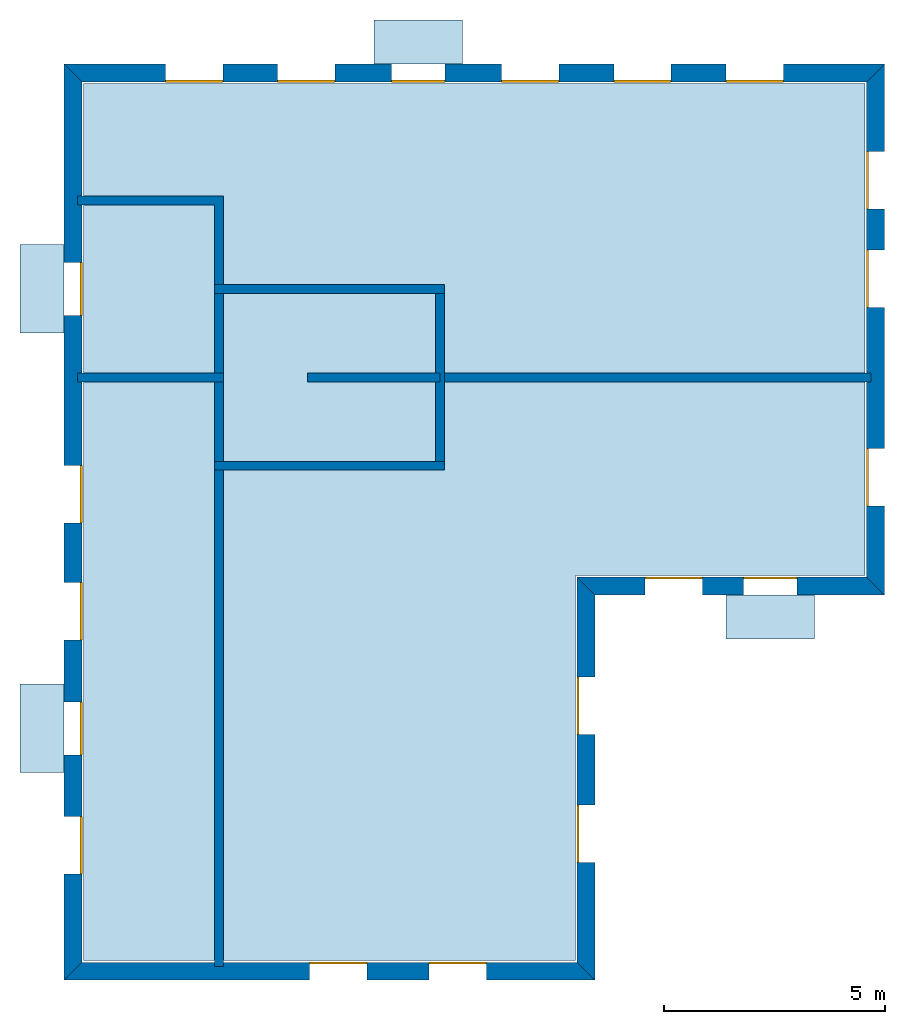
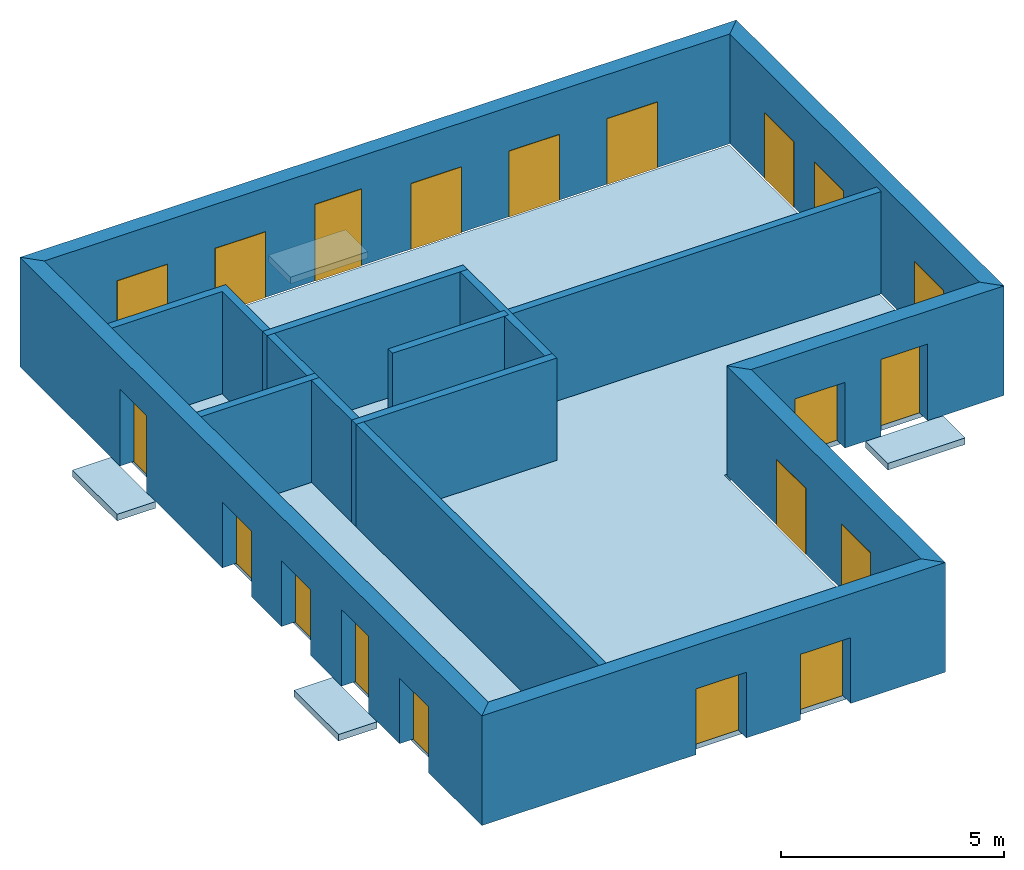
# One storey: 20 windows, 15 walls, 5 slabs, 20 openings.
"""IFC4 building model written with IfcOpenShell, lengths in metres."""

from ifc_helpers import new_model, si_unit, frame, origin_with_axes, place, context, subcontext, project, spatial, line, indexed_curve, outline, extrude, element, fill, save


model = new_model("IFC4")

# Units and contexts
model_context = context("Model", 3, precision=1e-05, world=origin_with_axes())
body_context = subcontext(model_context, "Body", "Model", "MODEL_VIEW")
ifc_project = project(units=[si_unit("AREAUNIT", "SQUARE_METRE"), si_unit("VOLUMEUNIT", "CUBIC_METRE"), si_unit("LENGTHUNIT", "METRE")], contexts=[model_context])

# Site, building, storey
site = spatial("IfcSite", under=ifc_project)
building = spatial("IfcBuilding", under=site, Name="Building 1")
storey_placement = place(None, frame((0.0, 0.0, 4.0), z_axis=(0.0, 0.0, 1.0), x_axis=(1.0, 0.0, 0.0)))
storey = spatial("IfcBuildingStorey", under=building, at=storey_placement, Name="02 Storey")

# Slabs
slab_1_placement = place(storey_placement, origin_with_axes())
element("IfcSlab", 1, at=slab_1_placement, inside=storey, Name="Slab", context=body_context, shape_type="SweptSolid", body=[
    extrude(outline(indexed_curve([(15.553354, 14.695575), (22.099464, 14.695575), (22.099464, 25.815575), (4.433354, 25.815575), (4.433354, 5.9882), (15.553354, 5.9882)], segments=[line(1, 2), line(2, 3), line(3, 4), line(4, 5), line(5, 6)])), origin_with_axes(), (0.0, 0.0, -1.0), 0.2),
])
slab_2_placement = place(storey_placement, origin_with_axes())
element("IfcSlab", 2, at=slab_2_placement, inside=storey, Name="Balcony", context=body_context, shape_type="SweptSolid", body=[
    extrude(outline(indexed_curve([(20.9574273333333, 14.255575), (20.9574273333333, 13.255575), (18.9574273333333, 13.255575), (18.9574273333333, 14.255575)], segments=[line(1, 2), line(2, 3), line(3, 4)])), origin_with_axes(), (0.0, 0.0, -1.0), 0.18),
])
slab_3_placement = place(storey_placement, origin_with_axes())
element("IfcSlab", 3, at=slab_3_placement, inside=storey, Name="Balcony", context=body_context, shape_type="SweptSolid", body=[
    extrude(outline(indexed_curve([(10.9988297142857, 26.255575), (10.9988297142857, 27.255575), (12.9988297142857, 27.255575), (12.9988297142857, 26.255575)], segments=[line(1, 2), line(2, 3), line(3, 4)])), origin_with_axes(), (0.0, 0.0, -1.0), 0.18),
])
slab_4_placement = place(storey_placement, origin_with_axes())
element("IfcSlab", 4, at=slab_4_placement, inside=storey, Name="Balcony", context=body_context, shape_type="SweptSolid", body=[
    extrude(outline(indexed_curve([(3.993354, 10.2388972), (2.993354, 10.2388972), (2.993354, 12.2388972), (3.993354, 12.2388972)], segments=[line(1, 2), line(2, 3), line(3, 4)])), origin_with_axes(), (0.0, 0.0, -1.0), 0.18),
])
slab_5_placement = place(storey_placement, origin_with_axes())
element("IfcSlab", 5, at=slab_5_placement, inside=storey, Name="Balcony", context=body_context, shape_type="SweptSolid", body=[
    extrude(outline(indexed_curve([(3.993354, 20.174943), (2.993354, 20.174943), (2.993354, 22.174943), (3.993354, 22.174943)], segments=[line(1, 2), line(2, 3), line(3, 4)])), origin_with_axes(), (0.0, 0.0, -1.0), 0.18),
])

# Walls
wall_1_placement = place(storey_placement, origin_with_axes())
element("IfcWall", 6, at=wall_1_placement, inside=storey, Name="Wall", context=body_context, shape_type="SweptSolid", body=[
    extrude(outline(indexed_curve([(22.239464, 19.274943), (12.393354, 19.274943), (12.393354, 19.074943), (22.239464, 19.074943)], segments=[line(1, 2), line(2, 3), line(3, 4)])), origin_with_axes(), (0.0, 0.0, 1.0), 2.8),
])
wall_2_placement = place(storey_placement, origin_with_axes())
element("IfcWall", 7, at=wall_2_placement, inside=storey, Name="Wall", context=body_context, shape_type="SweptSolid", body=[
    extrude(outline(indexed_curve([(7.593354, 17.274943), (7.393354, 17.274943), (7.393354, 5.8482), (7.593354, 5.8482)], segments=[line(1, 2), line(2, 3), line(3, 4)])), origin_with_axes(), (0.0, 0.0, 1.0), 2.8),
])
wall_3_placement = place(storey_placement, origin_with_axes())
element("IfcWall", 8, at=wall_3_placement, inside=storey, Name="Wall", context=body_context, shape_type="SweptSolid", body=[
    extrude(outline(indexed_curve([(7.593354, 19.274943), (4.293354, 19.274943), (4.293354, 19.074943), (7.593354, 19.074943)], segments=[line(1, 2), line(2, 3), line(3, 4)])), origin_with_axes(), (0.0, 0.0, 1.0), 2.8),
])
wall_4_placement = place(storey_placement, origin_with_axes())
element("IfcWall", 9, at=wall_4_placement, inside=storey, Name="Wall", context=body_context, shape_type="SweptSolid", body=[
    extrude(outline(indexed_curve([(7.593354, 23.274943), (4.293354, 23.274943), (4.293354, 23.074943), (7.393354, 23.074943), (7.393354, 21.074943), (7.593354, 21.074943)], segments=[line(1, 2), line(2, 3), line(3, 4), line(4, 5), line(5, 6)])), origin_with_axes(), (0.0, 0.0, 1.0), 2.8),
])

# Wall, openings, windows
wall_5_placement = place(storey_placement, origin_with_axes())
wall_5 = element("IfcWall", 10, at=wall_5_placement, inside=storey, Name="Facade", context=body_context, shape_type="SweptSolid", body=[
    extrude(outline(indexed_curve([(15.593354, 14.655575), (22.139464, 14.655575), (22.539464, 14.255575), (15.993354, 14.255575)], segments=[line(1, 2), line(2, 3), line(3, 4)])), origin_with_axes(), (0.0, 0.0, 1.0), 3.0),
])
opening_1_placement = place(wall_5_placement, origin_with_axes())
opening_1 = element("IfcOpeningElement", 11, at=opening_1_placement, cuts=wall_5, Name="Opening", context=body_context, shape_type="SweptSolid", body=[
    extrude(outline(indexed_curve([(17.1253906666667, 14.215575), (17.1253906666667, 14.715575), (18.4253906666667, 14.715575), (18.4253906666667, 14.215575)], segments=[line(1, 2), line(2, 3), line(3, 4)])), origin_with_axes(), (0.0, 0.0, 1.0), 1.8),
])
opening_2_placement = place(wall_5_placement, origin_with_axes())
opening_2 = element("IfcOpeningElement", 12, at=opening_2_placement, cuts=wall_5, Name="Opening", context=body_context, shape_type="SweptSolid", body=[
    extrude(outline(indexed_curve([(19.3574273333333, 14.215575), (19.3574273333333, 14.715575), (20.5574273333333, 14.715575), (20.5574273333333, 14.215575)], segments=[line(1, 2), line(2, 3), line(3, 4)])), origin_with_axes(), (0.0, 0.0, 1.0), 2.1),
])
window_1_placement = place(storey_placement, origin_with_axes())
window_1 = element("IfcWindow", 13, at=window_1_placement, inside=storey, Name="Window", PredefinedType="WINDOW", context=body_context, shape_type="SweptSolid", body=[
    extrude(outline(indexed_curve([(17.1253906666667, 14.615575), (17.1253906666667, 14.665575), (18.4253906666667, 14.665575), (18.4253906666667, 14.615575)], segments=[line(1, 2), line(2, 3), line(3, 4)])), origin_with_axes(), (0.0, 0.0, 1.0), 1.8),
])
fill(opening_1, window_1)
window_2_placement = place(storey_placement, origin_with_axes())
window_2 = element("IfcWindow", 14, at=window_2_placement, inside=storey, Name="Window", PredefinedType="WINDOW", context=body_context, shape_type="SweptSolid", body=[
    extrude(outline(indexed_curve([(19.3574273333333, 14.615575), (19.3574273333333, 14.665575), (20.5574273333333, 14.665575), (20.5574273333333, 14.615575)], segments=[line(1, 2), line(2, 3), line(3, 4)])), origin_with_axes(), (0.0, 0.0, 1.0), 2.1),
])
fill(opening_2, window_2)

wall_6_placement = place(storey_placement, origin_with_axes())
wall_6 = element("IfcWall", 15, at=wall_6_placement, inside=storey, Name="Facade", context=body_context, shape_type="SweptSolid", body=[
    extrude(outline(indexed_curve([(22.139464, 14.655575), (22.139464, 25.855575), (22.539464, 26.255575), (22.539464, 14.255575)], segments=[line(1, 2), line(2, 3), line(3, 4)])), origin_with_axes(), (0.0, 0.0, 1.0), 3.0),
])
opening_3_placement = place(wall_6_placement, origin_with_axes())
opening_3 = element("IfcOpeningElement", 16, at=opening_3_placement, cuts=wall_6, Name="Opening", context=body_context, shape_type="SweptSolid", body=[
    extrude(outline(indexed_curve([(22.579464, 16.265259), (22.079464, 16.265259), (22.079464, 17.565259), (22.579464, 17.565259)], segments=[line(1, 2), line(2, 3), line(3, 4)])), origin_with_axes(), (0.0, 0.0, 1.0), 1.8),
])
opening_4_placement = place(wall_6_placement, origin_with_axes())
opening_4 = element("IfcOpeningElement", 17, at=opening_4_placement, cuts=wall_6, Name="Opening", context=body_context, shape_type="SweptSolid", body=[
    extrude(outline(indexed_curve([(22.579464, 20.7518203333333), (22.079464, 20.7518203333333), (22.079464, 22.0518203333333), (22.579464, 22.0518203333333)], segments=[line(1, 2), line(2, 3), line(3, 4)])), origin_with_axes(), (0.0, 0.0, 1.0), 1.8),
])
opening_5_placement = place(wall_6_placement, origin_with_axes())
opening_5 = element("IfcOpeningElement", 18, at=opening_5_placement, cuts=wall_6, Name="Opening", context=body_context, shape_type="SweptSolid", body=[
    extrude(outline(indexed_curve([(22.579464, 22.9786976666667), (22.079464, 22.9786976666667), (22.079464, 24.2786976666667), (22.579464, 24.2786976666667)], segments=[line(1, 2), line(2, 3), line(3, 4)])), origin_with_axes(), (0.0, 0.0, 1.0), 1.8),
])
window_3_placement = place(storey_placement, origin_with_axes())
window_3 = element("IfcWindow", 19, at=window_3_placement, inside=storey, Name="Window", PredefinedType="WINDOW", context=body_context, shape_type="SweptSolid", body=[
    extrude(outline(indexed_curve([(22.179464, 16.265259), (22.129464, 16.265259), (22.129464, 17.565259), (22.179464, 17.565259)], segments=[line(1, 2), line(2, 3), line(3, 4)])), origin_with_axes(), (0.0, 0.0, 1.0), 1.8),
])
fill(opening_3, window_3)
window_4_placement = place(storey_placement, origin_with_axes())
window_4 = element("IfcWindow", 20, at=window_4_placement, inside=storey, Name="Window", PredefinedType="WINDOW", context=body_context, shape_type="SweptSolid", body=[
    extrude(outline(indexed_curve([(22.179464, 20.7518203333333), (22.129464, 20.7518203333333), (22.129464, 22.0518203333333), (22.179464, 22.0518203333333)], segments=[line(1, 2), line(2, 3), line(3, 4)])), origin_with_axes(), (0.0, 0.0, 1.0), 1.8),
])
fill(opening_4, window_4)
window_5_placement = place(storey_placement, origin_with_axes())
window_5 = element("IfcWindow", 21, at=window_5_placement, inside=storey, Name="Window", PredefinedType="WINDOW", context=body_context, shape_type="SweptSolid", body=[
    extrude(outline(indexed_curve([(22.179464, 22.9786976666667), (22.129464, 22.9786976666667), (22.129464, 24.2786976666667), (22.179464, 24.2786976666667)], segments=[line(1, 2), line(2, 3), line(3, 4)])), origin_with_axes(), (0.0, 0.0, 1.0), 1.8),
])
fill(opening_5, window_5)

wall_7_placement = place(storey_placement, origin_with_axes())
wall_7 = element("IfcWall", 22, at=wall_7_placement, inside=storey, Name="Facade", context=body_context, shape_type="SweptSolid", body=[
    extrude(outline(indexed_curve([(22.139464, 25.855575), (4.393354, 25.855575), (3.993354, 26.255575), (22.539464, 26.255575)], segments=[line(1, 2), line(2, 3), line(3, 4)])), origin_with_axes(), (0.0, 0.0, 1.0), 3.0),
])
opening_6_placement = place(wall_7_placement, origin_with_axes())
opening_6 = element("IfcOpeningElement", 23, at=opening_6_placement, cuts=wall_7, Name="Opening", context=body_context, shape_type="SweptSolid", body=[
    extrude(outline(indexed_curve([(20.2543054285714, 26.295575), (20.2543054285714, 25.795575), (18.9543054285714, 25.795575), (18.9543054285714, 26.295575)], segments=[line(1, 2), line(2, 3), line(3, 4)])), origin_with_axes(), (0.0, 0.0, 1.0), 1.8),
])
opening_7_placement = place(wall_7_placement, origin_with_axes())
opening_7 = element("IfcOpeningElement", 24, at=opening_7_placement, cuts=wall_7, Name="Opening", context=body_context, shape_type="SweptSolid", body=[
    extrude(outline(indexed_curve([(17.7191468571429, 26.295575), (17.7191468571429, 25.795575), (16.4191468571429, 25.795575), (16.4191468571429, 26.295575)], segments=[line(1, 2), line(2, 3), line(3, 4)])), origin_with_axes(), (0.0, 0.0, 1.0), 1.8),
])
opening_8_placement = place(wall_7_placement, origin_with_axes())
opening_8 = element("IfcOpeningElement", 25, at=opening_8_placement, cuts=wall_7, Name="Opening", context=body_context, shape_type="SweptSolid", body=[
    extrude(outline(indexed_curve([(15.1839882857143, 26.295575), (15.1839882857143, 25.795575), (13.8839882857143, 25.795575), (13.8839882857143, 26.295575)], segments=[line(1, 2), line(2, 3), line(3, 4)])), origin_with_axes(), (0.0, 0.0, 1.0), 1.8),
])
opening_9_placement = place(wall_7_placement, origin_with_axes())
opening_9 = element("IfcOpeningElement", 26, at=opening_9_placement, cuts=wall_7, Name="Opening", context=body_context, shape_type="SweptSolid", body=[
    extrude(outline(indexed_curve([(12.5988297142857, 26.295575), (12.5988297142857, 25.795575), (11.3988297142857, 25.795575), (11.3988297142857, 26.295575)], segments=[line(1, 2), line(2, 3), line(3, 4)])), origin_with_axes(), (0.0, 0.0, 1.0), 2.1),
])
opening_10_placement = place(wall_7_placement, origin_with_axes())
opening_10 = element("IfcOpeningElement", 27, at=opening_10_placement, cuts=wall_7, Name="Opening", context=body_context, shape_type="SweptSolid", body=[
    extrude(outline(indexed_curve([(10.1136711428571, 26.295575), (10.1136711428571, 25.795575), (8.81367114285714, 25.795575), (8.81367114285714, 26.295575)], segments=[line(1, 2), line(2, 3), line(3, 4)])), origin_with_axes(), (0.0, 0.0, 1.0), 1.8),
])
opening_11_placement = place(wall_7_placement, origin_with_axes())
opening_11 = element("IfcOpeningElement", 28, at=opening_11_placement, cuts=wall_7, Name="Opening", context=body_context, shape_type="SweptSolid", body=[
    extrude(outline(indexed_curve([(7.57851257142857, 26.295575), (7.57851257142857, 25.795575), (6.27851257142857, 25.795575), (6.27851257142857, 26.295575)], segments=[line(1, 2), line(2, 3), line(3, 4)])), origin_with_axes(), (0.0, 0.0, 1.0), 1.8),
])
window_6_placement = place(storey_placement, origin_with_axes())
window_6 = element("IfcWindow", 29, at=window_6_placement, inside=storey, Name="Window", PredefinedType="WINDOW", context=body_context, shape_type="SweptSolid", body=[
    extrude(outline(indexed_curve([(20.2543054285714, 25.895575), (20.2543054285714, 25.845575), (18.9543054285714, 25.845575), (18.9543054285714, 25.895575)], segments=[line(1, 2), line(2, 3), line(3, 4)])), origin_with_axes(), (0.0, 0.0, 1.0), 1.8),
])
fill(opening_6, window_6)
window_7_placement = place(storey_placement, origin_with_axes())
window_7 = element("IfcWindow", 30, at=window_7_placement, inside=storey, Name="Window", PredefinedType="WINDOW", context=body_context, shape_type="SweptSolid", body=[
    extrude(outline(indexed_curve([(17.7191468571429, 25.895575), (17.7191468571429, 25.845575), (16.4191468571429, 25.845575), (16.4191468571429, 25.895575)], segments=[line(1, 2), line(2, 3), line(3, 4)])), origin_with_axes(), (0.0, 0.0, 1.0), 1.8),
])
fill(opening_7, window_7)
window_8_placement = place(storey_placement, origin_with_axes())
window_8 = element("IfcWindow", 31, at=window_8_placement, inside=storey, Name="Window", PredefinedType="WINDOW", context=body_context, shape_type="SweptSolid", body=[
    extrude(outline(indexed_curve([(15.1839882857143, 25.895575), (15.1839882857143, 25.845575), (13.8839882857143, 25.845575), (13.8839882857143, 25.895575)], segments=[line(1, 2), line(2, 3), line(3, 4)])), origin_with_axes(), (0.0, 0.0, 1.0), 1.8),
])
fill(opening_8, window_8)
window_9_placement = place(storey_placement, origin_with_axes())
window_9 = element("IfcWindow", 32, at=window_9_placement, inside=storey, Name="Window", PredefinedType="WINDOW", context=body_context, shape_type="SweptSolid", body=[
    extrude(outline(indexed_curve([(12.5988297142857, 25.895575), (12.5988297142857, 25.845575), (11.3988297142857, 25.845575), (11.3988297142857, 25.895575)], segments=[line(1, 2), line(2, 3), line(3, 4)])), origin_with_axes(), (0.0, 0.0, 1.0), 2.1),
])
fill(opening_9, window_9)
window_10_placement = place(storey_placement, origin_with_axes())
window_10 = element("IfcWindow", 33, at=window_10_placement, inside=storey, Name="Window", PredefinedType="WINDOW", context=body_context, shape_type="SweptSolid", body=[
    extrude(outline(indexed_curve([(10.1136711428571, 25.895575), (10.1136711428571, 25.845575), (8.81367114285714, 25.845575), (8.81367114285714, 25.895575)], segments=[line(1, 2), line(2, 3), line(3, 4)])), origin_with_axes(), (0.0, 0.0, 1.0), 1.8),
])
fill(opening_10, window_10)
window_11_placement = place(storey_placement, origin_with_axes())
window_11 = element("IfcWindow", 34, at=window_11_placement, inside=storey, Name="Window", PredefinedType="WINDOW", context=body_context, shape_type="SweptSolid", body=[
    extrude(outline(indexed_curve([(7.57851257142857, 25.895575), (7.57851257142857, 25.845575), (6.27851257142857, 25.845575), (6.27851257142857, 25.895575)], segments=[line(1, 2), line(2, 3), line(3, 4)])), origin_with_axes(), (0.0, 0.0, 1.0), 1.8),
])
fill(opening_11, window_11)

wall_8_placement = place(storey_placement, origin_with_axes())
wall_8 = element("IfcWall", 35, at=wall_8_placement, inside=storey, Name="Facade", context=body_context, shape_type="SweptSolid", body=[
    extrude(outline(indexed_curve([(4.393354, 25.855575), (4.393354, 5.9482), (3.993354, 5.5482), (3.993354, 26.255575)], segments=[line(1, 2), line(2, 3), line(3, 4)])), origin_with_axes(), (0.0, 0.0, 1.0), 3.0),
])
opening_12_placement = place(wall_8_placement, origin_with_axes())
opening_12 = element("IfcOpeningElement", 36, at=opening_12_placement, cuts=wall_8, Name="Opening", context=body_context, shape_type="SweptSolid", body=[
    extrude(outline(indexed_curve([(3.953354, 17.1795944), (4.453354, 17.1795944), (4.453354, 15.8795944), (3.953354, 15.8795944)], segments=[line(1, 2), line(2, 3), line(3, 4)])), origin_with_axes(), (0.0, 0.0, 1.0), 1.8),
])
opening_13_placement = place(wall_8_placement, origin_with_axes())
opening_13 = element("IfcOpeningElement", 37, at=opening_13_placement, cuts=wall_8, Name="Opening", context=body_context, shape_type="SweptSolid", body=[
    extrude(outline(indexed_curve([(3.953354, 14.5342458), (4.453354, 14.5342458), (4.453354, 13.2342458), (3.953354, 13.2342458)], segments=[line(1, 2), line(2, 3), line(3, 4)])), origin_with_axes(), (0.0, 0.0, 1.0), 1.8),
])
opening_14_placement = place(wall_8_placement, origin_with_axes())
opening_14 = element("IfcOpeningElement", 38, at=opening_14_placement, cuts=wall_8, Name="Opening", context=body_context, shape_type="SweptSolid", body=[
    extrude(outline(indexed_curve([(3.953354, 11.8388972), (4.453354, 11.8388972), (4.453354, 10.6388972), (3.953354, 10.6388972)], segments=[line(1, 2), line(2, 3), line(3, 4)])), origin_with_axes(), (0.0, 0.0, 1.0), 2.1),
])
opening_15_placement = place(wall_8_placement, origin_with_axes())
opening_15 = element("IfcOpeningElement", 39, at=opening_15_placement, cuts=wall_8, Name="Opening", context=body_context, shape_type="SweptSolid", body=[
    extrude(outline(indexed_curve([(3.953354, 9.2435486), (4.453354, 9.2435486), (4.453354, 7.9435486), (3.953354, 7.9435486)], segments=[line(1, 2), line(2, 3), line(3, 4)])), origin_with_axes(), (0.0, 0.0, 1.0), 1.8),
])
opening_16_placement = place(wall_8_placement, origin_with_axes())
opening_16 = element("IfcOpeningElement", 40, at=opening_16_placement, cuts=wall_8, Name="Opening", context=body_context, shape_type="SweptSolid", body=[
    extrude(outline(indexed_curve([(3.953354, 21.774943), (4.453354, 21.774943), (4.453354, 20.574943), (3.953354, 20.574943)], segments=[line(1, 2), line(2, 3), line(3, 4)])), origin_with_axes(), (0.0, 0.0, 1.0), 2.1),
])
window_12_placement = place(storey_placement, origin_with_axes())
window_12 = element("IfcWindow", 41, at=window_12_placement, inside=storey, Name="Window", PredefinedType="WINDOW", context=body_context, shape_type="SweptSolid", body=[
    extrude(outline(indexed_curve([(4.353354, 17.1795944), (4.403354, 17.1795944), (4.403354, 15.8795944), (4.353354, 15.8795944)], segments=[line(1, 2), line(2, 3), line(3, 4)])), origin_with_axes(), (0.0, 0.0, 1.0), 1.8),
])
fill(opening_12, window_12)
window_13_placement = place(storey_placement, origin_with_axes())
window_13 = element("IfcWindow", 42, at=window_13_placement, inside=storey, Name="Window", PredefinedType="WINDOW", context=body_context, shape_type="SweptSolid", body=[
    extrude(outline(indexed_curve([(4.353354, 14.5342458), (4.403354, 14.5342458), (4.403354, 13.2342458), (4.353354, 13.2342458)], segments=[line(1, 2), line(2, 3), line(3, 4)])), origin_with_axes(), (0.0, 0.0, 1.0), 1.8),
])
fill(opening_13, window_13)
window_14_placement = place(storey_placement, origin_with_axes())
window_14 = element("IfcWindow", 43, at=window_14_placement, inside=storey, Name="Window", PredefinedType="WINDOW", context=body_context, shape_type="SweptSolid", body=[
    extrude(outline(indexed_curve([(4.353354, 11.8388972), (4.403354, 11.8388972), (4.403354, 10.6388972), (4.353354, 10.6388972)], segments=[line(1, 2), line(2, 3), line(3, 4)])), origin_with_axes(), (0.0, 0.0, 1.0), 2.1),
])
fill(opening_14, window_14)
window_15_placement = place(storey_placement, origin_with_axes())
window_15 = element("IfcWindow", 44, at=window_15_placement, inside=storey, Name="Window", PredefinedType="WINDOW", context=body_context, shape_type="SweptSolid", body=[
    extrude(outline(indexed_curve([(4.353354, 9.2435486), (4.403354, 9.2435486), (4.403354, 7.9435486), (4.353354, 7.9435486)], segments=[line(1, 2), line(2, 3), line(3, 4)])), origin_with_axes(), (0.0, 0.0, 1.0), 1.8),
])
fill(opening_15, window_15)
window_16_placement = place(storey_placement, origin_with_axes())
window_16 = element("IfcWindow", 45, at=window_16_placement, inside=storey, Name="Window", PredefinedType="WINDOW", context=body_context, shape_type="SweptSolid", body=[
    extrude(outline(indexed_curve([(4.353354, 21.774943), (4.403354, 21.774943), (4.403354, 20.574943), (4.353354, 20.574943)], segments=[line(1, 2), line(2, 3), line(3, 4)])), origin_with_axes(), (0.0, 0.0, 1.0), 2.1),
])
fill(opening_16, window_16)

wall_9_placement = place(storey_placement, origin_with_axes())
wall_9 = element("IfcWall", 46, at=wall_9_placement, inside=storey, Name="Facade", context=body_context, shape_type="SweptSolid", body=[
    extrude(outline(indexed_curve([(4.393354, 5.9482), (15.593354, 5.9482), (15.993354, 5.5482), (3.993354, 5.5482)], segments=[line(1, 2), line(2, 3), line(3, 4)])), origin_with_axes(), (0.0, 0.0, 1.0), 3.0),
])
opening_17_placement = place(wall_9_placement, origin_with_axes())
opening_17 = element("IfcOpeningElement", 47, at=opening_17_placement, cuts=wall_9, Name="Opening", context=body_context, shape_type="SweptSolid", body=[
    extrude(outline(indexed_curve([(9.543354, 5.5082), (9.543354, 6.0082), (10.843354, 6.0082), (10.843354, 5.5082)], segments=[line(1, 2), line(2, 3), line(3, 4)])), origin_with_axes(), (0.0, 0.0, 1.0), 1.8),
])
opening_18_placement = place(wall_9_placement, origin_with_axes())
opening_18 = element("IfcOpeningElement", 48, at=opening_18_placement, cuts=wall_9, Name="Opening", context=body_context, shape_type="SweptSolid", body=[
    extrude(outline(indexed_curve([(12.243354, 5.5082), (12.243354, 6.0082), (13.543354, 6.0082), (13.543354, 5.5082)], segments=[line(1, 2), line(2, 3), line(3, 4)])), origin_with_axes(), (0.0, 0.0, 1.0), 1.8),
])
window_17_placement = place(storey_placement, origin_with_axes())
window_17 = element("IfcWindow", 49, at=window_17_placement, inside=storey, Name="Window", PredefinedType="WINDOW", context=body_context, shape_type="SweptSolid", body=[
    extrude(outline(indexed_curve([(9.543354, 5.9082), (9.543354, 5.9582), (10.843354, 5.9582), (10.843354, 5.9082)], segments=[line(1, 2), line(2, 3), line(3, 4)])), origin_with_axes(), (0.0, 0.0, 1.0), 1.8),
])
fill(opening_17, window_17)
window_18_placement = place(storey_placement, origin_with_axes())
window_18 = element("IfcWindow", 50, at=window_18_placement, inside=storey, Name="Window", PredefinedType="WINDOW", context=body_context, shape_type="SweptSolid", body=[
    extrude(outline(indexed_curve([(12.243354, 5.9082), (12.243354, 5.9582), (13.543354, 5.9582), (13.543354, 5.9082)], segments=[line(1, 2), line(2, 3), line(3, 4)])), origin_with_axes(), (0.0, 0.0, 1.0), 1.8),
])
fill(opening_18, window_18)

wall_10_placement = place(storey_placement, origin_with_axes())
wall_10 = element("IfcWall", 51, at=wall_10_placement, inside=storey, Name="Facade", context=body_context, shape_type="SweptSolid", body=[
    extrude(outline(indexed_curve([(15.593354, 5.9482), (15.593354, 14.655575), (15.993354, 14.255575), (15.993354, 5.5482)], segments=[line(1, 2), line(2, 3), line(3, 4)])), origin_with_axes(), (0.0, 0.0, 1.0), 3.0),
])
opening_19_placement = place(wall_10_placement, origin_with_axes())
opening_19 = element("IfcOpeningElement", 52, at=opening_19_placement, cuts=wall_10, Name="Opening", context=body_context, shape_type="SweptSolid", body=[
    extrude(outline(indexed_curve([(16.033354, 8.20065833333333), (15.533354, 8.20065833333333), (15.533354, 9.50065833333333), (16.033354, 9.50065833333333)], segments=[line(1, 2), line(2, 3), line(3, 4)])), origin_with_axes(), (0.0, 0.0, 1.0), 1.8),
])
opening_20_placement = place(wall_10_placement, origin_with_axes())
opening_20 = element("IfcOpeningElement", 53, at=opening_20_placement, cuts=wall_10, Name="Opening", context=body_context, shape_type="SweptSolid", body=[
    extrude(outline(indexed_curve([(16.033354, 11.1031166666667), (15.533354, 11.1031166666667), (15.533354, 12.4031166666667), (16.033354, 12.4031166666667)], segments=[line(1, 2), line(2, 3), line(3, 4)])), origin_with_axes(), (0.0, 0.0, 1.0), 1.8),
])
window_19_placement = place(storey_placement, origin_with_axes())
window_19 = element("IfcWindow", 54, at=window_19_placement, inside=storey, Name="Window", PredefinedType="WINDOW", context=body_context, shape_type="SweptSolid", body=[
    extrude(outline(indexed_curve([(15.633354, 8.20065833333333), (15.583354, 8.20065833333333), (15.583354, 9.50065833333333), (15.633354, 9.50065833333333)], segments=[line(1, 2), line(2, 3), line(3, 4)])), origin_with_axes(), (0.0, 0.0, 1.0), 1.8),
])
fill(opening_19, window_19)
window_20_placement = place(storey_placement, origin_with_axes())
window_20 = element("IfcWindow", 55, at=window_20_placement, inside=storey, Name="Window", PredefinedType="WINDOW", context=body_context, shape_type="SweptSolid", body=[
    extrude(outline(indexed_curve([(15.633354, 11.1031166666667), (15.583354, 11.1031166666667), (15.583354, 12.4031166666667), (15.633354, 12.4031166666667)], segments=[line(1, 2), line(2, 3), line(3, 4)])), origin_with_axes(), (0.0, 0.0, 1.0), 1.8),
])
fill(opening_20, window_20)

# Walls
wall_11_placement = place(storey_placement, origin_with_axes())
element("IfcWall", 56, at=wall_11_placement, inside=storey, Name="CoreWall", context=body_context, shape_type="SweptSolid", body=[
    extrude(outline(indexed_curve([(12.593354, 21.274943), (7.393354, 21.274943), (7.393354, 21.074943), (12.593354, 21.074943)], segments=[line(1, 2), line(2, 3), line(3, 4)])), origin_with_axes(), (0.0, 0.0, 1.0), 2.8),
])
wall_12_placement = place(storey_placement, origin_with_axes())
element("IfcWall", 57, at=wall_12_placement, inside=storey, Name="CoreWall", context=body_context, shape_type="SweptSolid", body=[
    extrude(outline(indexed_curve([(7.393354, 17.074943), (12.593354, 17.074943), (12.593354, 17.274943), (7.393354, 17.274943)], segments=[line(1, 2), line(2, 3), line(3, 4)])), origin_with_axes(), (0.0, 0.0, 1.0), 2.8),
])
wall_13_placement = place(storey_placement, origin_with_axes())
element("IfcWall", 58, at=wall_13_placement, inside=storey, Name="CoreWall", context=body_context, shape_type="SweptSolid", body=[
    extrude(outline(indexed_curve([(7.593354, 17.274943), (7.593354, 21.074943), (7.393354, 21.074943), (7.393354, 17.274943)], segments=[line(1, 2), line(2, 3), line(3, 4)])), origin_with_axes(), (0.0, 0.0, 1.0), 2.8),
])
wall_14_placement = place(storey_placement, origin_with_axes())
element("IfcWall", 59, at=wall_14_placement, inside=storey, Name="CoreWall", context=body_context, shape_type="SweptSolid", body=[
    extrude(outline(indexed_curve([(12.393354, 21.074943), (12.393354, 17.274943), (12.593354, 17.274943), (12.593354, 21.074943)], segments=[line(1, 2), line(2, 3), line(3, 4)])), origin_with_axes(), (0.0, 0.0, 1.0), 2.8),
])
wall_15_placement = place(storey_placement, origin_with_axes())
element("IfcWall", 60, at=wall_15_placement, inside=storey, Name="CoreWall", context=body_context, shape_type="SweptSolid", body=[
    extrude(outline(indexed_curve([(12.493354, 19.274943), (9.493354, 19.274943), (9.493354, 19.074943), (12.493354, 19.074943)], segments=[line(1, 2), line(2, 3), line(3, 4)])), origin_with_axes(), (0.0, 0.0, 1.0), 2.8),
])

save(model, "model.ifc")
